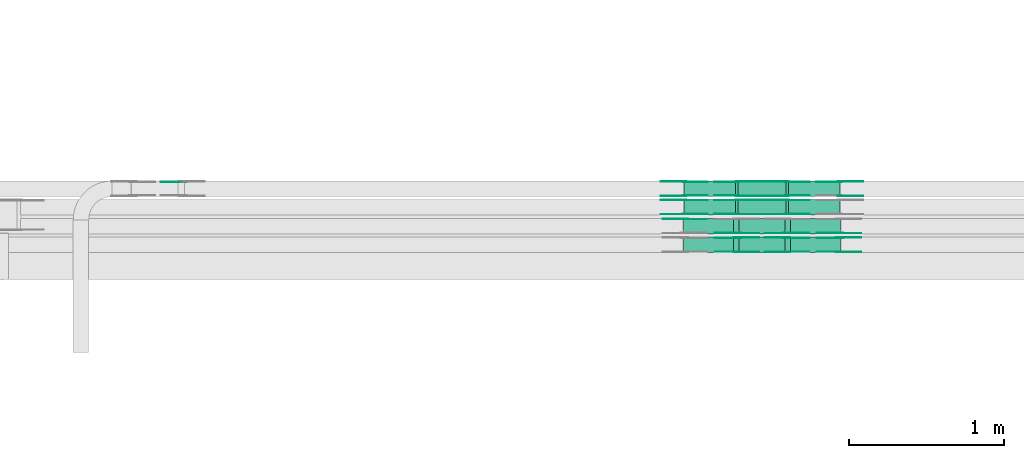
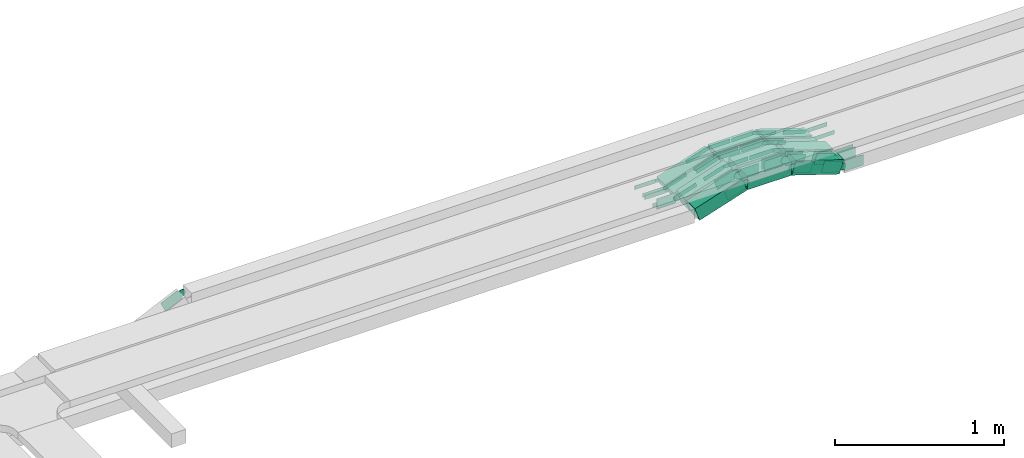
# One storey, part 9 of 19: 48 flow fittings, 12 flow segments.
"""IFC2X3 building model written with IfcOpenShell, lengths in millimetres."""

from ifc_helpers import new_model, entity, si_unit, converted_unit, derived_unit, direction, frame, frame_2d, origin, origin_2d_with_axis, place, context, subcontext, project, spatial, polyline, circle_curve, parameter, trimmed, segment, composite_curve, rectangle, outline, extrude, source, transform, mapped, material, type_object, type_shapes, element, save


model = new_model("IFC2X3")

# Units and contexts
model_context = context("Model", 3, precision=0.01, world=origin(), true_north=direction((6.12303176911189e-17, 1.0)))
body_context = subcontext(model_context, "Body", "Model", "MODEL_VIEW")
ifc_project = project(units=[si_unit("LENGTHUNIT", "METRE", prefix="MILLI"), si_unit("AREAUNIT", "SQUARE_METRE"), si_unit("VOLUMEUNIT", "CUBIC_METRE"), converted_unit("PLANEANGLEUNIT", "DEGREE", entity("IfcRatioMeasure", 0.0174532925199433), si_unit("PLANEANGLEUNIT", "RADIAN"), dimensions=[0, 0, 0, 0, 0, 0, 0]), si_unit("MASSUNIT", "GRAM", prefix="KILO"), derived_unit("MASSDENSITYUNIT", [(si_unit("MASSUNIT", "GRAM", prefix="KILO"), 1), (si_unit("LENGTHUNIT", "METRE"), -3)]), derived_unit("MOMENTOFINERTIAUNIT", [(si_unit("LENGTHUNIT", "METRE"), 4)]), si_unit("TIMEUNIT", "SECOND"), si_unit("FREQUENCYUNIT", "HERTZ"), si_unit("THERMODYNAMICTEMPERATUREUNIT", "DEGREE_CELSIUS"), derived_unit("THERMALTRANSMITTANCEUNIT", [(si_unit("MASSUNIT", "GRAM", prefix="KILO"), 1), (si_unit("THERMODYNAMICTEMPERATUREUNIT", "KELVIN"), -1), (si_unit("TIMEUNIT", "SECOND"), -3)]), derived_unit("VOLUMETRICFLOWRATEUNIT", [(si_unit("LENGTHUNIT", "METRE"), 3), (si_unit("TIMEUNIT", "SECOND"), -1)]), derived_unit("MASSFLOWRATEUNIT", [(si_unit("MASSUNIT", "GRAM", prefix="KILO"), 1), (si_unit("TIMEUNIT", "SECOND"), -1)]), derived_unit("ROTATIONALFREQUENCYUNIT", [(si_unit("TIMEUNIT", "SECOND"), -1)]), si_unit("ELECTRICCURRENTUNIT", "AMPERE"), si_unit("ELECTRICVOLTAGEUNIT", "VOLT"), si_unit("POWERUNIT", "WATT"), si_unit("FORCEUNIT", "NEWTON", prefix="KILO"), si_unit("ILLUMINANCEUNIT", "LUX"), si_unit("LUMINOUSFLUXUNIT", "LUMEN"), si_unit("LUMINOUSINTENSITYUNIT", "CANDELA"), derived_unit("USERDEFINED", [(si_unit("MASSUNIT", "GRAM", prefix="KILO"), -1), (si_unit("LENGTHUNIT", "METRE"), -2), (si_unit("TIMEUNIT", "SECOND"), 3), (si_unit("LUMINOUSFLUXUNIT", "LUMEN"), 1)]), derived_unit("LINEARVELOCITYUNIT", [(si_unit("LENGTHUNIT", "METRE"), 1), (si_unit("TIMEUNIT", "SECOND"), -1)]), si_unit("PRESSUREUNIT", "PASCAL"), derived_unit("USERDEFINED", [(si_unit("LENGTHUNIT", "METRE"), -2), (si_unit("MASSUNIT", "GRAM", prefix="KILO"), 1), (si_unit("TIMEUNIT", "SECOND"), -2)]), derived_unit("LINEARFORCEUNIT", [(si_unit("MASSUNIT", "GRAM", prefix="KILO"), 1), (si_unit("LENGTHUNIT", "METRE"), 1), (si_unit("TIMEUNIT", "SECOND"), -2), (si_unit("LENGTHUNIT", "METRE"), -1)]), derived_unit("PLANARFORCEUNIT", [(si_unit("MASSUNIT", "GRAM", prefix="KILO"), 1), (si_unit("LENGTHUNIT", "METRE"), 1), (si_unit("TIMEUNIT", "SECOND"), -2), (si_unit("LENGTHUNIT", "METRE"), -2)])], contexts=[model_context])

# Site, building, storey
site_placement = place(None, origin())
site = spatial("IfcSite", under=ifc_project, at=site_placement, CompositionType="ELEMENT")
building_placement = place(site_placement, origin())
building = spatial("IfcBuilding", under=site, at=building_placement, CompositionType="ELEMENT")
storey_placement = place(building_placement, frame((0.0, 0.0, 12000.0)))
storey = spatial("IfcBuildingStorey", under=building, at=storey_placement, CompositionType="ELEMENT", Elevation=12000.0)

# Flow segments
cable_carrier_segment_type = type_object("IfcCableCarrierSegmentType", PredefinedType="CABLETRAYSEGMENT")
flow_segment_1_placement = place(storey_placement, frame((23686.35, 14792.5, 2502.95)))
element("IfcFlowSegment", 1, at=flow_segment_1_placement, inside=storey, type_object=cable_carrier_segment_type, context=body_context, shape_type="SweptSolid", body=[
    extrude(rectangle(XDim=50.0000000000005, YDim=99.9999999999989, at=origin_2d_with_axis()), frame((7.73, 50.0, 131.57), z_axis=(0.951056516295132, 0.0, -0.309016994375015), x_axis=(0.309016994375015, 0.0, 0.951056516295132)), (0.0, 0.0, 1.0), 348.813702461178),
])
flow_segment_2_placement = place(storey_placement, frame((23376.4, 14792.5, 2611.25)))
element("IfcFlowSegment", 2, at=flow_segment_2_placement, inside=storey, type_object=cable_carrier_segment_type, context=body_context, shape_type="SweptSolid", body=[
    extrude(rectangle(XDim=306.763415131531, YDim=99.9999999999989, at=origin_2d_with_axis()), frame((153.38, 50.0, 0.0), z_axis=(0.0, 0.0, 1.0), x_axis=(-1.0, 0.0, 0.0)), (0.0, 0.0, 1.0), 50.0000000000016),
])
flow_segment_3_placement = place(storey_placement, frame((23026.02, 14792.5, 2502.95)))
element("IfcFlowSegment", 3, at=flow_segment_3_placement, inside=storey, type_object=cable_carrier_segment_type, context=body_context, shape_type="SweptSolid", body=[
    extrude(rectangle(XDim=49.9999999999991, YDim=99.9999999999989, at=frame_2d((0.0, 0.0), x_axis=(0.0, 1.0))), frame((7.73, 50.0, 23.78), z_axis=(0.951056516295132, 0.0, 0.309016994375015), x_axis=(0.0, 1.0, 0.0)), (0.0, 0.0, 1.0), 348.813702461196),
])
flow_segment_4_placement = place(storey_placement, frame((23686.35, 14673.63, 2502.95)))
element("IfcFlowSegment", 4, at=flow_segment_4_placement, inside=storey, type_object=cable_carrier_segment_type, context=body_context, shape_type="SweptSolid", body=[
    extrude(rectangle(XDim=50.0000000000005, YDim=99.9999999999989, at=origin_2d_with_axis()), frame((7.73, 50.0, 131.57), z_axis=(0.951056516295132, 0.0, -0.309016994375015), x_axis=(0.309016994375015, 0.0, 0.951056516295132)), (0.0, 0.0, 1.0), 348.813702461366),
])
flow_segment_5_placement = place(storey_placement, frame((23376.4, 14673.63, 2611.25)))
element("IfcFlowSegment", 5, at=flow_segment_5_placement, inside=storey, type_object=cable_carrier_segment_type, context=body_context, shape_type="SweptSolid", body=[
    extrude(rectangle(XDim=306.763415131523, YDim=99.9999999999989, at=origin_2d_with_axis()), frame((153.38, 50.0, 0.0), z_axis=(0.0, 0.0, 1.0), x_axis=(-1.0, 0.0, 0.0)), (0.0, 0.0, 1.0), 50.0000000000016),
])
flow_segment_6_placement = place(storey_placement, frame((23026.02, 14673.63, 2502.95)))
element("IfcFlowSegment", 6, at=flow_segment_6_placement, inside=storey, type_object=cable_carrier_segment_type, context=body_context, shape_type="SweptSolid", body=[
    extrude(rectangle(XDim=50.0000000000005, YDim=99.9999999999989, at=frame_2d((0.0, 0.0), x_axis=(0.0, 1.0))), frame((7.73, 50.0, 23.78), z_axis=(0.951056516295132, 0.0, 0.309016994375015), x_axis=(0.0, 1.0, 0.0)), (0.0, 0.0, 1.0), 348.813702461398),
])
flow_segment_7_placement = place(storey_placement, frame((23681.31, 14551.42, 2505.4)))
element("IfcFlowSegment", 7, at=flow_segment_7_placement, inside=storey, type_object=cable_carrier_segment_type, context=body_context, shape_type="SweptSolid", body=[
    extrude(rectangle(XDim=99.9999999999988, YDim=99.9999999999989, at=origin_2d_with_axis()), frame((15.45, 50.0, 152.9), z_axis=(0.95105651629513, 0.0, -0.309016994375022), x_axis=(0.309016994375022, 0.0, 0.95105651629513)), (0.0, 0.0, 1.0), 340.894480445313),
])
flow_segment_8_placement = place(storey_placement, frame((23379.28, 14551.42, 2611.25)))
element("IfcFlowSegment", 8, at=flow_segment_8_placement, inside=storey, type_object=cable_carrier_segment_type, context=body_context, shape_type="SweptSolid", body=[
    extrude(rectangle(XDim=298.844193115582, YDim=99.9999999999989, at=origin_2d_with_axis()), frame((149.42, 50.0, 0.0), z_axis=(0.0, 0.0, 1.0), x_axis=(-1.0, 0.0, 0.0)), (0.0, 0.0, 1.0), 99.9999999999989),
])
flow_segment_9_placement = place(storey_placement, frame((23020.99, 14551.42, 2505.4)))
element("IfcFlowSegment", 9, at=flow_segment_9_placement, inside=storey, type_object=cable_carrier_segment_type, context=body_context, shape_type="SweptSolid", body=[
    extrude(rectangle(XDim=100.000000000001, YDim=99.9999999999989, at=frame_2d((0.0, 0.0), x_axis=(0.0, 1.0))), frame((15.45, 50.0, 47.55), z_axis=(0.951056516295132, 0.0, 0.309016994375015), x_axis=(0.0, 1.0, 0.0)), (0.0, 0.0, 1.0), 340.884030478122),
])
flow_segment_10_placement = place(storey_placement, frame((23681.31, 14429.99, 2505.4)))
element("IfcFlowSegment", 10, at=flow_segment_10_placement, inside=storey, type_object=cable_carrier_segment_type, context=body_context, shape_type="SweptSolid", body=[
    extrude(rectangle(XDim=100.000000000001, YDim=99.9999999999989, at=origin_2d_with_axis()), frame((15.45, 50.0, 152.9), z_axis=(0.951056516295132, 0.0, -0.309016994375015), x_axis=(0.309016994375015, 0.0, 0.951056516295132)), (0.0, 0.0, 1.0), 340.894480445308),
])
flow_segment_11_placement = place(storey_placement, frame((23379.28, 14429.99, 2611.25)))
element("IfcFlowSegment", 11, at=flow_segment_11_placement, inside=storey, type_object=cable_carrier_segment_type, context=body_context, shape_type="SweptSolid", body=[
    extrude(rectangle(XDim=298.844193115587, YDim=99.9999999999989, at=origin_2d_with_axis()), frame((149.42, 50.0, 0.0), z_axis=(0.0, 0.0, 1.0), x_axis=(-1.0, 0.0, 0.0)), (0.0, 0.0, 1.0), 99.9999999999989),
])
flow_segment_12_placement = place(storey_placement, frame((23021.01, 14429.99, 2505.41)))
element("IfcFlowSegment", 12, at=flow_segment_12_placement, inside=storey, type_object=cable_carrier_segment_type, context=body_context, shape_type="SweptSolid", body=[
    extrude(rectangle(XDim=100.000000000001, YDim=99.9999999999989, at=frame_2d((0.0, 0.0), x_axis=(0.0, 1.0))), frame((15.45, 50.0, 47.55), z_axis=(0.951056516295132, 0.0, 0.309016994375015), x_axis=(0.0, 1.0, 0.0)), (0.0, 0.0, 1.0), 340.867962260358),
])

# Flow fittings
ifc_material = material(Name="G")
cable_carrier_fitting_type_1 = type_object("IfcCableCarrierFittingType", PredefinedType="NOTDEFINED", material=ifc_material)
shared_shape_1 = source(origin(), body_context, "Body", "SweptSolid", [
    extrude(outline(composite_curve([segment(trimmed(circle_curve(frame_2d((-44.59, 0.0), x_axis=(1.0, 0.0)), 12.5), [parameter(90.0000000000007)], [parameter(270.0)], True, "PARAMETER"), True, "CONTINUOUS"), segment(polyline([(-44.59, -12.5), (-33.09, -12.5)]), True, "CONTINUOUS"), segment(polyline([(-33.09, -12.5), (-31.23, -14.5)]), True, "CONTINUOUS"), segment(polyline([(-31.23, -14.5), (108.91, -14.5)]), True, "CONTINUOUS"), segment(polyline([(108.91, -14.5), (108.91, 14.5)]), True, "CONTINUOUS"), segment(polyline([(108.91, 14.5), (-31.23, 14.5)]), True, "CONTINUOUS"), segment(polyline([(-31.23, 14.5), (-33.09, 12.5)]), True, "CONTINUOUS"), segment(polyline([(-33.09, 12.5), (-44.59, 12.5)]), True, "CONTINUOUS")], self_intersect=False)), frame((44.59, 0.0, 0.0), z_axis=(0.0, 0.0, -1.0), x_axis=(1.0, 0.0, 0.0)), (0.0, 0.0, -1.0), 2.0),
])
type_shapes(cable_carrier_fitting_type_1, [shared_shape_1])
flow_fitting_1_placement = place(storey_placement, frame((23688.75, 14797.04, 2636.25), z_axis=(0.0, -1.0, 0.0), x_axis=(-1.0, 0.0, 0.0)))
element("IfcFlowFitting", 13, at=flow_fitting_1_placement, inside=storey, type_object=cable_carrier_fitting_type_1, material=ifc_material, context=body_context, shape_type="MappedRepresentation", body=[
    mapped(shared_shape_1, transform((0.0, 0.0, 0.0), scale=1.0)),
])
cable_carrier_fitting_type_2 = type_object("IfcCableCarrierFittingType", PredefinedType="NOTDEFINED", material=ifc_material)
type_shapes(cable_carrier_fitting_type_2, [shared_shape_1])
flow_fitting_2_placement = place(storey_placement, frame((23688.75, 14885.96, 2636.25), z_axis=(0.0, 1.0, 0.0), x_axis=(0.951056516295156, 0.0, -0.309016994374939)))
element("IfcFlowFitting", 14, at=flow_fitting_2_placement, inside=storey, type_object=cable_carrier_fitting_type_2, material=ifc_material, context=body_context, shape_type="MappedRepresentation", body=[
    mapped(shared_shape_1, transform((0.0, 0.0, 0.0), scale=1.0)),
])
flow_fitting_3_placement = place(storey_placement, frame((23370.8, 14887.96, 2636.25), z_axis=(0.0, 1.0, 0.0), x_axis=(1.0, 0.0, 0.0)))
element("IfcFlowFitting", 15, at=flow_fitting_3_placement, inside=storey, type_object=cable_carrier_fitting_type_1, material=ifc_material, context=body_context, shape_type="MappedRepresentation", body=[
    mapped(shared_shape_1, transform((0.0, 0.0, 0.0), scale=1.0)),
])
flow_fitting_4_placement = place(storey_placement, frame((23370.8, 14799.04, 2636.25), z_axis=(0.0, -1.0, 0.0), x_axis=(-0.951056516295156, 0.0, -0.309016994374939)))
element("IfcFlowFitting", 16, at=flow_fitting_4_placement, inside=storey, type_object=cable_carrier_fitting_type_2, material=ifc_material, context=body_context, shape_type="MappedRepresentation", body=[
    mapped(shared_shape_1, transform((0.0, 0.0, 0.0), scale=1.0)),
])
flow_fitting_5_placement = place(storey_placement, frame((23688.75, 14678.17, 2636.25), z_axis=(0.0, -1.0, 0.0), x_axis=(-1.0, 0.0, 0.0)))
element("IfcFlowFitting", 17, at=flow_fitting_5_placement, inside=storey, type_object=cable_carrier_fitting_type_1, material=ifc_material, context=body_context, shape_type="MappedRepresentation", body=[
    mapped(shared_shape_1, transform((0.0, 0.0, 0.0), scale=1.0)),
])
flow_fitting_6_placement = place(storey_placement, frame((23688.75, 14767.09, 2636.25), z_axis=(0.0, 1.0, 0.0), x_axis=(0.951056516295156, 0.0, -0.309016994374939)))
element("IfcFlowFitting", 18, at=flow_fitting_6_placement, inside=storey, type_object=cable_carrier_fitting_type_2, material=ifc_material, context=body_context, shape_type="MappedRepresentation", body=[
    mapped(shared_shape_1, transform((0.0, 0.0, 0.0), scale=1.0)),
])
flow_fitting_7_placement = place(storey_placement, frame((23370.8, 14769.09, 2636.25), z_axis=(0.0, 1.0, 0.0), x_axis=(1.0, 0.0, 0.0)))
element("IfcFlowFitting", 19, at=flow_fitting_7_placement, inside=storey, type_object=cable_carrier_fitting_type_1, material=ifc_material, context=body_context, shape_type="MappedRepresentation", body=[
    mapped(shared_shape_1, transform((0.0, 0.0, 0.0), scale=1.0)),
])
flow_fitting_8_placement = place(storey_placement, frame((23370.8, 14680.17, 2636.25), z_axis=(0.0, -1.0, 0.0), x_axis=(-0.951056516295156, 0.0, -0.309016994374939)))
element("IfcFlowFitting", 20, at=flow_fitting_8_placement, inside=storey, type_object=cable_carrier_fitting_type_2, material=ifc_material, context=body_context, shape_type="MappedRepresentation", body=[
    mapped(shared_shape_1, transform((0.0, 0.0, 0.0), scale=1.0)),
])
flow_fitting_9_placement = place(storey_placement, frame((24031.13, 14797.04, 2525.0), z_axis=(0.0, -1.0, 0.0), x_axis=(1.0, 0.0, 0.0)))
element("IfcFlowFitting", 21, at=flow_fitting_9_placement, inside=storey, type_object=cable_carrier_fitting_type_1, material=ifc_material, context=body_context, shape_type="MappedRepresentation", body=[
    mapped(shared_shape_1, transform((0.0, 0.0, 0.0), scale=1.0)),
])
flow_fitting_10_placement = place(storey_placement, frame((24031.13, 14885.96, 2525.0), z_axis=(0.0, 1.0, 0.0), x_axis=(-0.951056516295159, 0.0, 0.309016994374931)))
element("IfcFlowFitting", 22, at=flow_fitting_10_placement, inside=storey, type_object=cable_carrier_fitting_type_2, material=ifc_material, context=body_context, shape_type="MappedRepresentation", body=[
    mapped(shared_shape_1, transform((0.0, 0.0, 0.0), scale=1.0)),
])
flow_fitting_11_placement = place(storey_placement, frame((23028.42, 14887.96, 2525.0), z_axis=(0.0, 1.0, 0.0), x_axis=(-1.0, 0.0, 0.0)))
element("IfcFlowFitting", 23, at=flow_fitting_11_placement, inside=storey, type_object=cable_carrier_fitting_type_1, material=ifc_material, context=body_context, shape_type="MappedRepresentation", body=[
    mapped(shared_shape_1, transform((0.0, 0.0, 0.0), scale=1.0)),
])
flow_fitting_12_placement = place(storey_placement, frame((23028.42, 14799.04, 2525.0), z_axis=(0.0, -1.0, 0.0), x_axis=(0.951056516295161, 0.0, 0.309016994374923)))
element("IfcFlowFitting", 24, at=flow_fitting_12_placement, inside=storey, type_object=cable_carrier_fitting_type_2, material=ifc_material, context=body_context, shape_type="MappedRepresentation", body=[
    mapped(shared_shape_1, transform((0.0, 0.0, 0.0), scale=1.0)),
])
flow_fitting_13_placement = place(storey_placement, frame((23028.42, 14769.09, 2525.0), z_axis=(0.0, 1.0, 0.0), x_axis=(-1.0, 0.0, 0.0)))
element("IfcFlowFitting", 25, at=flow_fitting_13_placement, inside=storey, type_object=cable_carrier_fitting_type_1, material=ifc_material, context=body_context, shape_type="MappedRepresentation", body=[
    mapped(shared_shape_1, transform((0.0, 0.0, 0.0), scale=1.0)),
])
flow_fitting_14_placement = place(storey_placement, frame((23028.42, 14680.17, 2525.0), z_axis=(0.0, -1.0, 0.0), x_axis=(0.95105651629516, 0.0, 0.309016994374927)))
element("IfcFlowFitting", 26, at=flow_fitting_14_placement, inside=storey, type_object=cable_carrier_fitting_type_2, material=ifc_material, context=body_context, shape_type="MappedRepresentation", body=[
    mapped(shared_shape_1, transform((0.0, 0.0, 0.0), scale=1.0)),
])
cable_carrier_fitting_type_3 = type_object("IfcCableCarrierFittingType", PredefinedType="NOTDEFINED", material=ifc_material)
shared_shape_2 = source(origin(), body_context, "Body", "SweptSolid", [
    extrude(outline(composite_curve([segment(trimmed(circle_curve(frame_2d((-44.59, 0.0), x_axis=(1.0, 0.0)), 12.5), [parameter(90.0000000000007)], [parameter(270.0)], True, "PARAMETER"), True, "CONTINUOUS"), segment(polyline([(-44.59, -12.5), (-33.09, -12.5)]), True, "CONTINUOUS"), segment(polyline([(-33.09, -12.5), (-31.23, -14.5)]), True, "CONTINUOUS"), segment(polyline([(-31.23, -14.5), (108.91, -14.5)]), True, "CONTINUOUS"), segment(polyline([(108.91, -14.5), (108.91, 14.5)]), True, "CONTINUOUS"), segment(polyline([(108.91, 14.5), (-31.23, 14.5)]), True, "CONTINUOUS"), segment(polyline([(-31.23, 14.5), (-33.09, 12.5)]), True, "CONTINUOUS"), segment(polyline([(-33.09, 12.5), (-44.59, 12.5)]), True, "CONTINUOUS")], self_intersect=False)), frame((44.59, 0.0, 0.0)), (0.0, 0.0, 1.0), 2.0),
])
type_shapes(cable_carrier_fitting_type_3, [shared_shape_2])
flow_fitting_15_placement = place(storey_placement, frame((23688.75, 14887.96, 2636.25), z_axis=(0.0, 1.0, 0.0), x_axis=(-1.0, 0.0, 0.0)))
element("IfcFlowFitting", 27, at=flow_fitting_15_placement, inside=storey, type_object=cable_carrier_fitting_type_3, material=ifc_material, context=body_context, shape_type="MappedRepresentation", body=[
    mapped(shared_shape_2, transform((0.0, 0.0, 0.0), scale=1.0)),
])
cable_carrier_fitting_type_4 = type_object("IfcCableCarrierFittingType", PredefinedType="NOTDEFINED", material=ifc_material)
type_shapes(cable_carrier_fitting_type_4, [shared_shape_2])
flow_fitting_16_placement = place(storey_placement, frame((23688.75, 14799.04, 2636.25), z_axis=(0.0, -1.0, 0.0), x_axis=(0.951056516295156, 0.0, -0.309016994374939)))
element("IfcFlowFitting", 28, at=flow_fitting_16_placement, inside=storey, type_object=cable_carrier_fitting_type_4, material=ifc_material, context=body_context, shape_type="MappedRepresentation", body=[
    mapped(shared_shape_2, transform((0.0, 0.0, 0.0), scale=1.0)),
])
flow_fitting_17_placement = place(storey_placement, frame((23370.8, 14797.04, 2636.25), z_axis=(0.0, -1.0, 0.0), x_axis=(1.0, 0.0, 0.0)))
element("IfcFlowFitting", 29, at=flow_fitting_17_placement, inside=storey, type_object=cable_carrier_fitting_type_3, material=ifc_material, context=body_context, shape_type="MappedRepresentation", body=[
    mapped(shared_shape_2, transform((0.0, 0.0, 0.0), scale=1.0)),
])
flow_fitting_18_placement = place(storey_placement, frame((23370.8, 14885.96, 2636.25), z_axis=(0.0, 1.0, 0.0), x_axis=(-0.951056516295156, 0.0, -0.309016994374939)))
element("IfcFlowFitting", 30, at=flow_fitting_18_placement, inside=storey, type_object=cable_carrier_fitting_type_4, material=ifc_material, context=body_context, shape_type="MappedRepresentation", body=[
    mapped(shared_shape_2, transform((0.0, 0.0, 0.0), scale=1.0)),
])
flow_fitting_19_placement = place(storey_placement, frame((23688.75, 14769.09, 2636.25), z_axis=(0.0, 1.0, 0.0), x_axis=(-1.0, 0.0, 0.0)))
element("IfcFlowFitting", 31, at=flow_fitting_19_placement, inside=storey, type_object=cable_carrier_fitting_type_3, material=ifc_material, context=body_context, shape_type="MappedRepresentation", body=[
    mapped(shared_shape_2, transform((0.0, 0.0, 0.0), scale=1.0)),
])
flow_fitting_20_placement = place(storey_placement, frame((23688.75, 14680.17, 2636.25), z_axis=(0.0, -1.0, 0.0), x_axis=(0.951056516295156, 0.0, -0.309016994374939)))
element("IfcFlowFitting", 32, at=flow_fitting_20_placement, inside=storey, type_object=cable_carrier_fitting_type_4, material=ifc_material, context=body_context, shape_type="MappedRepresentation", body=[
    mapped(shared_shape_2, transform((0.0, 0.0, 0.0), scale=1.0)),
])
flow_fitting_21_placement = place(storey_placement, frame((23370.8, 14678.17, 2636.25), z_axis=(0.0, -1.0, 0.0), x_axis=(1.0, 0.0, 0.0)))
element("IfcFlowFitting", 33, at=flow_fitting_21_placement, inside=storey, type_object=cable_carrier_fitting_type_3, material=ifc_material, context=body_context, shape_type="MappedRepresentation", body=[
    mapped(shared_shape_2, transform((0.0, 0.0, 0.0), scale=1.0)),
])
flow_fitting_22_placement = place(storey_placement, frame((23370.8, 14767.09, 2636.25), z_axis=(0.0, 1.0, 0.0), x_axis=(-0.951056516295156, 0.0, -0.309016994374939)))
element("IfcFlowFitting", 34, at=flow_fitting_22_placement, inside=storey, type_object=cable_carrier_fitting_type_4, material=ifc_material, context=body_context, shape_type="MappedRepresentation", body=[
    mapped(shared_shape_2, transform((0.0, 0.0, 0.0), scale=1.0)),
])
for number, where, z_axis, x_axis in (
    (35, (24031.13, 14887.96, 2525.0), (0.0, 1.0, 0.0), (1.0, 0.0, 0.0)),
    (36, (23028.42, 14797.04, 2525.0), (0.0, -1.0, 0.0), (-1.0, 0.0, 0.0)),
):
    element("IfcFlowFitting", number, at=place(storey_placement, frame(where, z_axis=z_axis, x_axis=x_axis)), inside=storey, type_object=cable_carrier_fitting_type_3, material=ifc_material, context=body_context, shape_type="MappedRepresentation", body=[
        mapped(shared_shape_2, transform((0.0, 0.0, 0.0), scale=1.0)),
    ])
flow_fitting_23_placement = place(storey_placement, frame((23028.42, 14885.96, 2525.0), z_axis=(0.0, 1.0, 0.0), x_axis=(0.951056516295161, 0.0, 0.309016994374923)))
element("IfcFlowFitting", 37, at=flow_fitting_23_placement, inside=storey, type_object=cable_carrier_fitting_type_4, material=ifc_material, context=body_context, shape_type="MappedRepresentation", body=[
    mapped(shared_shape_2, transform((0.0, 0.0, 0.0), scale=1.0)),
])
flow_fitting_24_placement = place(storey_placement, frame((23028.42, 14678.17, 2525.0), z_axis=(0.0, -1.0, 0.0), x_axis=(-1.0, 0.0, 0.0)))
element("IfcFlowFitting", 38, at=flow_fitting_24_placement, inside=storey, type_object=cable_carrier_fitting_type_3, material=ifc_material, context=body_context, shape_type="MappedRepresentation", body=[
    mapped(shared_shape_2, transform((0.0, 0.0, 0.0), scale=1.0)),
])
flow_fitting_25_placement = place(storey_placement, frame((23028.42, 14767.09, 2525.0), z_axis=(0.0, 1.0, 0.0), x_axis=(0.95105651629516, 0.0, 0.309016994374927)))
element("IfcFlowFitting", 39, at=flow_fitting_25_placement, inside=storey, type_object=cable_carrier_fitting_type_4, material=ifc_material, context=body_context, shape_type="MappedRepresentation", body=[
    mapped(shared_shape_2, transform((0.0, 0.0, 0.0), scale=1.0)),
])
cable_carrier_fitting_type_5 = type_object("IfcCableCarrierFittingType", PredefinedType="NOTDEFINED", material=ifc_material)
shared_shape_3 = source(origin(), body_context, "Body", "SweptSolid", [
    extrude(outline(composite_curve([segment(trimmed(circle_curve(frame_2d((-41.47, 0.0), x_axis=(1.0, 0.0)), 25.0), [parameter(90.0000000000007)], [parameter(270.0)], True, "PARAMETER"), True, "CONTINUOUS"), segment(polyline([(-41.47, -25.0), (-29.97, -25.0)]), True, "CONTINUOUS"), segment(polyline([(-29.97, -25.0), (-28.1, -38.5)]), True, "CONTINUOUS"), segment(polyline([(-28.1, -38.5), (99.53, -38.5)]), True, "CONTINUOUS"), segment(polyline([(99.53, -38.5), (99.53, 38.5)]), True, "CONTINUOUS"), segment(polyline([(99.53, 38.5), (-28.1, 38.5)]), True, "CONTINUOUS"), segment(polyline([(-28.1, 38.5), (-29.97, 25.0)]), True, "CONTINUOUS"), segment(polyline([(-29.97, 25.0), (-41.47, 25.0)]), True, "CONTINUOUS")], self_intersect=False)), frame((41.47, 0.0, 0.0), z_axis=(0.0, 0.0, -1.0), x_axis=(1.0, 0.0, 0.0)), (0.0, 0.0, -1.0), 2.0),
])
type_shapes(cable_carrier_fitting_type_5, [shared_shape_3])
flow_fitting_26_placement = place(storey_placement, frame((23687.68, 14555.96, 2661.25), z_axis=(0.0, -1.0, 0.0), x_axis=(-1.0, 0.0, 0.0)))
element("IfcFlowFitting", 40, at=flow_fitting_26_placement, inside=storey, type_object=cable_carrier_fitting_type_5, material=ifc_material, context=body_context, shape_type="MappedRepresentation", body=[
    mapped(shared_shape_3, transform((0.0, 0.0, 0.0), scale=1.0)),
])
cable_carrier_fitting_type_6 = type_object("IfcCableCarrierFittingType", PredefinedType="NOTDEFINED", material=ifc_material)
type_shapes(cable_carrier_fitting_type_6, [shared_shape_3])
flow_fitting_27_placement = place(storey_placement, frame((23369.73, 14557.96, 2661.25), z_axis=(0.0, -1.0, 0.0), x_axis=(-0.951056516295156, 0.0, -0.309016994374939)))
element("IfcFlowFitting", 41, at=flow_fitting_27_placement, inside=storey, type_object=cable_carrier_fitting_type_6, material=ifc_material, context=body_context, shape_type="MappedRepresentation", body=[
    mapped(shared_shape_3, transform((0.0, 0.0, 0.0), scale=1.0)),
])
for number, where, z_axis, x_axis in (
    (42, (23027.35, 14646.88, 2550.0), (0.0, 1.0, 0.0), (-0.999999928726835, 0.0, 0.000377553074818682)),
    (43, (24030.06, 14555.96, 2550.0), (0.0, -1.0, 0.0), (1.0, 0.0, 0.0)),
    (44, (23687.68, 14434.53, 2661.25), (0.0, -1.0, 0.0), (-1.0, 0.0, 0.0)),
):
    element("IfcFlowFitting", number, at=place(storey_placement, frame(where, z_axis=z_axis, x_axis=x_axis)), inside=storey, type_object=cable_carrier_fitting_type_5, material=ifc_material, context=body_context, shape_type="MappedRepresentation", body=[
        mapped(shared_shape_3, transform((0.0, 0.0, 0.0), scale=1.0)),
    ])
flow_fitting_28_placement = place(storey_placement, frame((23687.68, 14523.45, 2661.25), z_axis=(0.0, 1.0, 0.0), x_axis=(0.951056516295156, 0.0, -0.309016994374939)))
element("IfcFlowFitting", 45, at=flow_fitting_28_placement, inside=storey, type_object=cable_carrier_fitting_type_6, material=ifc_material, context=body_context, shape_type="MappedRepresentation", body=[
    mapped(shared_shape_3, transform((0.0, 0.0, 0.0), scale=1.0)),
])
flow_fitting_29_placement = place(storey_placement, frame((23369.73, 14525.45, 2661.25), z_axis=(0.0, 1.0, 0.0), x_axis=(1.0, 0.0, 0.0)))
element("IfcFlowFitting", 46, at=flow_fitting_29_placement, inside=storey, type_object=cable_carrier_fitting_type_5, material=ifc_material, context=body_context, shape_type="MappedRepresentation", body=[
    mapped(shared_shape_3, transform((0.0, 0.0, 0.0), scale=1.0)),
])
flow_fitting_30_placement = place(storey_placement, frame((23369.73, 14436.53, 2661.25), z_axis=(0.0, -1.0, 0.0), x_axis=(-0.951056516295156, 0.0, -0.309016994374939)))
element("IfcFlowFitting", 47, at=flow_fitting_30_placement, inside=storey, type_object=cable_carrier_fitting_type_6, material=ifc_material, context=body_context, shape_type="MappedRepresentation", body=[
    mapped(shared_shape_3, transform((0.0, 0.0, 0.0), scale=1.0)),
])
flow_fitting_31_placement = place(storey_placement, frame((24030.06, 14434.53, 2550.0), z_axis=(0.0, -1.0, 0.0), x_axis=(1.0, 0.0, 0.0)))
element("IfcFlowFitting", 48, at=flow_fitting_31_placement, inside=storey, type_object=cable_carrier_fitting_type_5, material=ifc_material, context=body_context, shape_type="MappedRepresentation", body=[
    mapped(shared_shape_3, transform((0.0, 0.0, 0.0), scale=1.0)),
])
flow_fitting_32_placement = place(storey_placement, frame((24030.06, 14523.45, 2550.0), z_axis=(0.0, 1.0, 0.0), x_axis=(-0.951056516295155, 0.0, 0.309016994374944)))
element("IfcFlowFitting", 49, at=flow_fitting_32_placement, inside=storey, type_object=cable_carrier_fitting_type_6, material=ifc_material, context=body_context, shape_type="MappedRepresentation", body=[
    mapped(shared_shape_3, transform((0.0, 0.0, 0.0), scale=1.0)),
])
cable_carrier_fitting_type_7 = type_object("IfcCableCarrierFittingType", PredefinedType="NOTDEFINED", material=ifc_material)
shared_shape_4 = source(origin(), body_context, "Body", "SweptSolid", [
    extrude(outline(composite_curve([segment(trimmed(circle_curve(frame_2d((-41.47, 0.0), x_axis=(1.0, 0.0)), 25.0), [parameter(90.0000000000007)], [parameter(270.0)], True, "PARAMETER"), True, "CONTINUOUS"), segment(polyline([(-41.47, -25.0), (-29.97, -25.0)]), True, "CONTINUOUS"), segment(polyline([(-29.97, -25.0), (-28.1, -38.5)]), True, "CONTINUOUS"), segment(polyline([(-28.1, -38.5), (99.53, -38.5)]), True, "CONTINUOUS"), segment(polyline([(99.53, -38.5), (99.53, 38.5)]), True, "CONTINUOUS"), segment(polyline([(99.53, 38.5), (-28.1, 38.5)]), True, "CONTINUOUS"), segment(polyline([(-28.1, 38.5), (-29.97, 25.0)]), True, "CONTINUOUS"), segment(polyline([(-29.97, 25.0), (-41.47, 25.0)]), True, "CONTINUOUS")], self_intersect=False)), frame((41.47, 0.0, 0.0)), (0.0, 0.0, 1.0), 2.0),
])
type_shapes(cable_carrier_fitting_type_7, [shared_shape_4])
for number, where, z_axis, x_axis in (
    (50, (19785.09, 14885.96, 2850.0), (0.0, 1.0, 0.0), (-0.906307787034621, 0.0, -0.422618261745051)),
    (51, (23687.68, 14557.96, 2661.25), (0.0, -1.0, 0.0), (0.951056516295156, 0.0, -0.309016994374939)),
):
    element("IfcFlowFitting", number, at=place(storey_placement, frame(where, z_axis=z_axis, x_axis=x_axis)), inside=storey, type_object=cable_carrier_fitting_type_7, material=ifc_material, context=body_context, shape_type="MappedRepresentation", body=[
        mapped(shared_shape_4, transform((0.0, 0.0, 0.0), scale=1.0)),
    ])
cable_carrier_fitting_type_8 = type_object("IfcCableCarrierFittingType", PredefinedType="NOTDEFINED", material=ifc_material)
type_shapes(cable_carrier_fitting_type_8, [shared_shape_4])
flow_fitting_33_placement = place(storey_placement, frame((23369.73, 14555.96, 2661.25), z_axis=(0.0, -1.0, 0.0), x_axis=(1.0, 0.0, 0.0)))
element("IfcFlowFitting", 52, at=flow_fitting_33_placement, inside=storey, type_object=cable_carrier_fitting_type_8, material=ifc_material, context=body_context, shape_type="MappedRepresentation", body=[
    mapped(shared_shape_4, transform((0.0, 0.0, 0.0), scale=1.0)),
])
for number, where, z_axis, x_axis in (
    (53, (23027.35, 14644.88, 2550.0), (0.0, 1.0, 0.0), (0.951056516295155, 0.0, 0.309016994374943)),
    (54, (24030.06, 14557.96, 2550.0), (0.0, -1.0, 0.0), (-0.951056516295154, 0.0, 0.309016994374947)),
):
    element("IfcFlowFitting", number, at=place(storey_placement, frame(where, z_axis=z_axis, x_axis=x_axis)), inside=storey, type_object=cable_carrier_fitting_type_7, material=ifc_material, context=body_context, shape_type="MappedRepresentation", body=[
        mapped(shared_shape_4, transform((0.0, 0.0, 0.0), scale=1.0)),
    ])
flow_fitting_34_placement = place(storey_placement, frame((23687.68, 14525.45, 2661.25), z_axis=(0.0, 1.0, 0.0), x_axis=(-1.0, 0.0, 0.0)))
element("IfcFlowFitting", 55, at=flow_fitting_34_placement, inside=storey, type_object=cable_carrier_fitting_type_8, material=ifc_material, context=body_context, shape_type="MappedRepresentation", body=[
    mapped(shared_shape_4, transform((0.0, 0.0, 0.0), scale=1.0)),
])
flow_fitting_35_placement = place(storey_placement, frame((23687.68, 14436.53, 2661.25), z_axis=(0.0, -1.0, 0.0), x_axis=(0.951056516295156, 0.0, -0.309016994374939)))
element("IfcFlowFitting", 56, at=flow_fitting_35_placement, inside=storey, type_object=cable_carrier_fitting_type_7, material=ifc_material, context=body_context, shape_type="MappedRepresentation", body=[
    mapped(shared_shape_4, transform((0.0, 0.0, 0.0), scale=1.0)),
])
flow_fitting_36_placement = place(storey_placement, frame((23369.73, 14434.53, 2661.25), z_axis=(0.0, -1.0, 0.0), x_axis=(1.0, 0.0, 0.0)))
element("IfcFlowFitting", 57, at=flow_fitting_36_placement, inside=storey, type_object=cable_carrier_fitting_type_8, material=ifc_material, context=body_context, shape_type="MappedRepresentation", body=[
    mapped(shared_shape_4, transform((0.0, 0.0, 0.0), scale=1.0)),
])
flow_fitting_37_placement = place(storey_placement, frame((23369.73, 14523.45, 2661.25), z_axis=(0.0, 1.0, 0.0), x_axis=(-0.951056516295156, 0.0, -0.309016994374939)))
element("IfcFlowFitting", 58, at=flow_fitting_37_placement, inside=storey, type_object=cable_carrier_fitting_type_7, material=ifc_material, context=body_context, shape_type="MappedRepresentation", body=[
    mapped(shared_shape_4, transform((0.0, 0.0, 0.0), scale=1.0)),
])
flow_fitting_38_placement = place(storey_placement, frame((24030.06, 14525.45, 2550.0), z_axis=(0.0, 1.0, 0.0), x_axis=(1.0, 0.0, 0.0)))
element("IfcFlowFitting", 59, at=flow_fitting_38_placement, inside=storey, type_object=cable_carrier_fitting_type_8, material=ifc_material, context=body_context, shape_type="MappedRepresentation", body=[
    mapped(shared_shape_4, transform((0.0, 0.0, 0.0), scale=1.0)),
])
flow_fitting_39_placement = place(storey_placement, frame((24030.06, 14436.53, 2550.0), z_axis=(0.0, -1.0, 0.0), x_axis=(-0.951056516295155, 0.0, 0.309016994374944)))
element("IfcFlowFitting", 60, at=flow_fitting_39_placement, inside=storey, type_object=cable_carrier_fitting_type_7, material=ifc_material, context=body_context, shape_type="MappedRepresentation", body=[
    mapped(shared_shape_4, transform((0.0, 0.0, 0.0), scale=1.0)),
])

save(model, "model.ifc")
